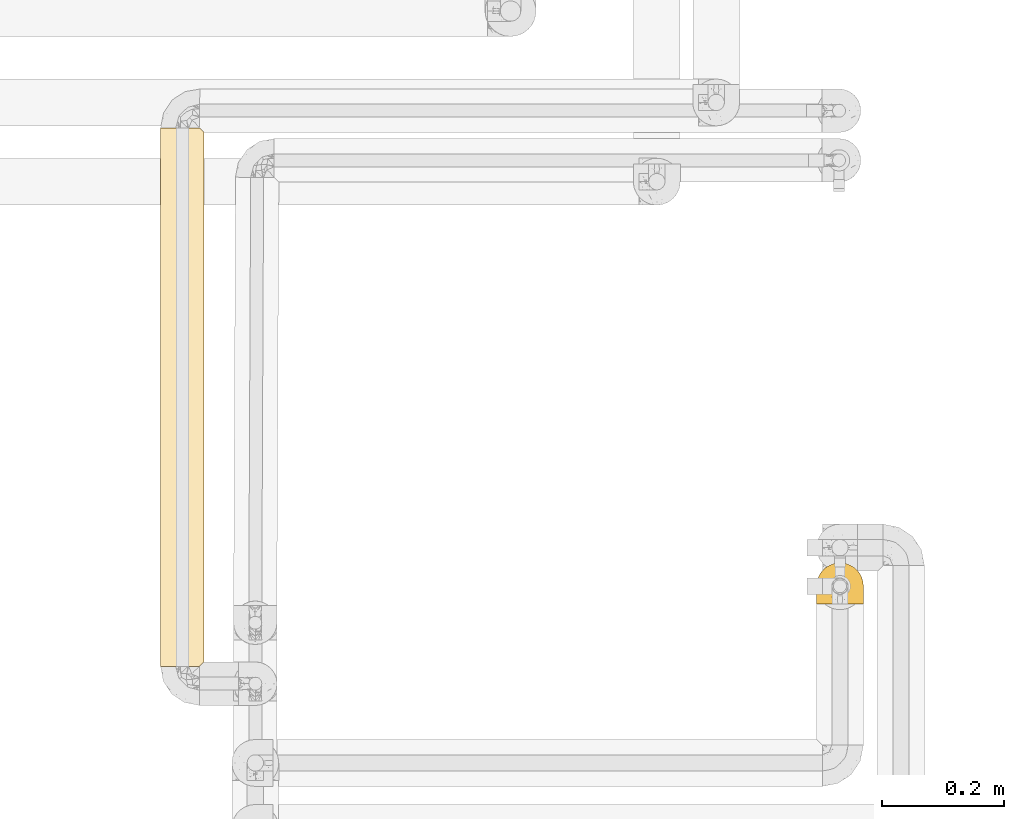
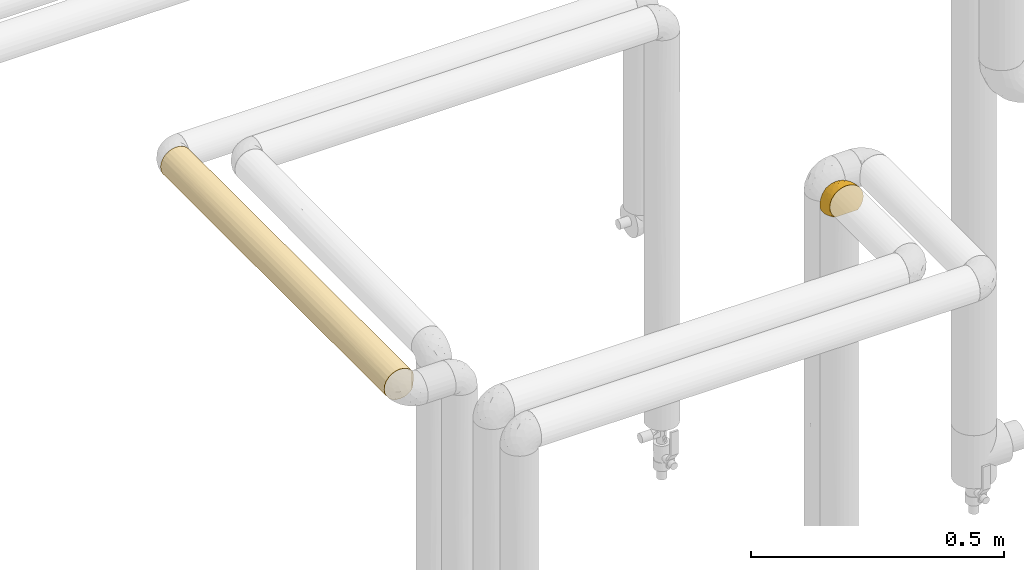
# One storey, part 87 of 827: 2 coverings.
"""IFC2X3 building model written with IfcOpenShell, lengths in millimetres."""

from ifc_helpers import new_model, entity, si_unit, converted_unit, derived_unit, direction, frame, origin, place, context, subcontext, project, spatial, faceted_brep, element, save


model = new_model("IFC2X3")

# Units and contexts
model_context = context("Model", 3, precision=0.01, world=origin(), true_north=direction((6.12303176911189e-17, 1.0)))
body_context = subcontext(model_context, "Body", "Model", "MODEL_VIEW")
ifc_project = project(units=[si_unit("LENGTHUNIT", "METRE", prefix="MILLI"), si_unit("AREAUNIT", "SQUARE_METRE"), si_unit("VOLUMEUNIT", "CUBIC_METRE"), converted_unit("PLANEANGLEUNIT", "DEGREE", entity("IfcRatioMeasure", 0.0174532925199433), si_unit("PLANEANGLEUNIT", "RADIAN"), dimensions=[0, 0, 0, 0, 0, 0, 0]), si_unit("MASSUNIT", "GRAM", prefix="KILO"), derived_unit("MASSDENSITYUNIT", [(si_unit("MASSUNIT", "GRAM", prefix="KILO"), 1), (si_unit("LENGTHUNIT", "METRE"), -3)]), derived_unit("MOMENTOFINERTIAUNIT", [(si_unit("LENGTHUNIT", "METRE"), 4)]), si_unit("TIMEUNIT", "SECOND"), si_unit("FREQUENCYUNIT", "HERTZ"), si_unit("THERMODYNAMICTEMPERATUREUNIT", "DEGREE_CELSIUS"), derived_unit("THERMALTRANSMITTANCEUNIT", [(si_unit("MASSUNIT", "GRAM", prefix="KILO"), 1), (si_unit("THERMODYNAMICTEMPERATUREUNIT", "KELVIN"), -1), (si_unit("TIMEUNIT", "SECOND"), -3)]), derived_unit("VOLUMETRICFLOWRATEUNIT", [(si_unit("LENGTHUNIT", "METRE"), 3), (si_unit("TIMEUNIT", "SECOND"), -1)]), derived_unit("MASSFLOWRATEUNIT", [(si_unit("MASSUNIT", "GRAM", prefix="KILO"), 1), (si_unit("TIMEUNIT", "SECOND"), -1)]), derived_unit("ROTATIONALFREQUENCYUNIT", [(si_unit("TIMEUNIT", "SECOND"), -1)]), si_unit("ELECTRICCURRENTUNIT", "AMPERE"), si_unit("ELECTRICVOLTAGEUNIT", "VOLT"), si_unit("POWERUNIT", "WATT"), si_unit("FORCEUNIT", "NEWTON", prefix="KILO"), si_unit("ILLUMINANCEUNIT", "LUX"), si_unit("LUMINOUSFLUXUNIT", "LUMEN"), si_unit("LUMINOUSINTENSITYUNIT", "CANDELA"), derived_unit("USERDEFINED", [(si_unit("MASSUNIT", "GRAM", prefix="KILO"), -1), (si_unit("LENGTHUNIT", "METRE"), -2), (si_unit("TIMEUNIT", "SECOND"), 3), (si_unit("LUMINOUSFLUXUNIT", "LUMEN"), 1)]), derived_unit("LINEARVELOCITYUNIT", [(si_unit("LENGTHUNIT", "METRE"), 1), (si_unit("TIMEUNIT", "SECOND"), -1)]), si_unit("PRESSUREUNIT", "PASCAL"), derived_unit("USERDEFINED", [(si_unit("LENGTHUNIT", "METRE"), -2), (si_unit("MASSUNIT", "GRAM", prefix="KILO"), 1), (si_unit("TIMEUNIT", "SECOND"), -2)]), derived_unit("LINEARFORCEUNIT", [(si_unit("MASSUNIT", "GRAM", prefix="KILO"), 1), (si_unit("LENGTHUNIT", "METRE"), 1), (si_unit("TIMEUNIT", "SECOND"), -2), (si_unit("LENGTHUNIT", "METRE"), -1)]), derived_unit("PLANARFORCEUNIT", [(si_unit("MASSUNIT", "GRAM", prefix="KILO"), 1), (si_unit("LENGTHUNIT", "METRE"), 1), (si_unit("TIMEUNIT", "SECOND"), -2), (si_unit("LENGTHUNIT", "METRE"), -2)])], contexts=[model_context])

# Site, building, storey
site_placement = place(None, origin())
site = spatial("IfcSite", under=ifc_project, at=site_placement, CompositionType="ELEMENT")
building_placement = place(site_placement, origin())
building = spatial("IfcBuilding", under=site, at=building_placement, CompositionType="ELEMENT")
storey_placement = place(building_placement, frame((0.0, 0.0, 28200.0)))
storey = spatial("IfcBuildingStorey", under=building, at=storey_placement, Name="08", CompositionType="ELEMENT", Elevation=28200.0)

# Coverings
covering_1_placement = place(storey_placement, frame((18846.09, 12125.48, 1869.3)))
element("IfcCovering", 1, at=covering_1_placement, inside=storey, Name=":ADSK_", ObjectType=":ADSK_", PredefinedType="INSULATION", context=body_context, shape_type="Brep", body=[
    faceted_brep([(5.41, 47.38, 1.6), (9.99, 54.67, 1.6), (16.08, 60.76, 1.6), (23.37, 65.34, 1.6), (31.49, 68.18, 1.6), (40.05, 69.15, 1.6), (48.61, 68.18, 1.6), (56.73, 65.33, 1.6), (64.02, 60.75, 1.6), (70.11, 54.66, 1.6), (74.69, 47.37, 1.6), (77.53, 39.25, 1.6), (78.5, 30.7, 1.6), (77.63, 22.59, 1.6), (75.08, 14.86, 1.6), (70.97, 7.84, 1.6), (65.47, 1.85, 1.6), (63.27, 1.85, 1.6), (61.53, 1.85, 1.6), (59.57, 1.85, 1.6), (57.6, 1.85, 1.6), (55.63, 1.85, 1.6), (53.67, 1.85, 1.6), (51.7, 1.85, 1.6), (49.73, 1.85, 1.6), (47.54, 1.85, 1.6), (45.34, 1.85, 1.6), (43.15, 1.85, 1.6), (40.96, 1.85, 1.6), (38.76, 1.85, 1.6), (36.57, 1.85, 1.6), (34.37, 1.85, 1.6), (32.18, 1.85, 1.6), (29.98, 1.85, 1.6), (27.79, 1.85, 1.6), (25.6, 1.85, 1.6), (23.4, 1.85, 1.6), (21.21, 1.85, 1.6), (19.01, 1.85, 1.6), (16.82, 1.85, 1.6), (14.62, 1.85, 1.6), (9.12, 7.85, 1.6), (5.0, 14.88, 1.6), (2.46, 22.61, 1.6), (1.6, 30.7, 1.6), (2.56, 39.26, 1.6), (65.47, 1.6, 1.85), (70.97, 1.6, 7.85), (75.09, 1.6, 14.87), (77.63, 1.6, 22.6), (78.5, 1.6, 30.7), (77.19, 1.6, 40.65), (73.34, 1.6, 49.92), (67.23, 1.6, 57.88), (59.27, 1.6, 63.99), (50.0, 1.6, 67.84), (40.05, 1.6, 69.15), (30.09, 1.6, 67.84), (20.82, 1.6, 63.99), (12.86, 1.6, 57.88), (6.75, 1.6, 49.92), (2.91, 1.6, 40.65), (1.6, 1.6, 30.7), (2.46, 1.6, 22.6), (5.0, 1.6, 14.87), (9.12, 1.6, 7.85), (14.62, 1.6, 1.85), (16.82, 1.6, 1.85), (17.8, 1.6, 1.85), (19.39, 1.6, 1.85), (20.98, 1.6, 1.85), (22.57, 1.6, 1.85), (24.16, 1.6, 1.85), (25.75, 1.6, 1.85), (27.33, 1.6, 1.85), (28.92, 1.6, 1.85), (30.51, 1.6, 1.85), (32.1, 1.6, 1.85), (33.69, 1.6, 1.85), (35.28, 1.6, 1.85), (36.87, 1.6, 1.85), (38.46, 1.6, 1.85), (40.05, 1.6, 1.85), (41.63, 1.6, 1.85), (43.22, 1.6, 1.85), (44.81, 1.6, 1.85), (46.4, 1.6, 1.85), (47.99, 1.6, 1.85), (49.58, 1.6, 1.85), (51.17, 1.6, 1.85), (52.76, 1.6, 1.85), (54.72, 1.6, 1.85), (56.69, 1.6, 1.85), (58.88, 1.6, 1.85), (61.08, 1.6, 1.85), (63.27, 1.6, 1.85), (37.77, 1.78, 1.77), (36.07, 1.77, 1.78), (32.96, 1.78, 1.77), (31.36, 1.77, 1.77), (56.52, 1.79, 1.76), (54.96, 1.78, 1.77), (18.75, 1.76, 1.79), (58.07, 1.77, 1.78), (50.37, 1.77, 1.78), (23.36, 1.76, 1.78), (24.95, 1.77, 1.78), (42.43, 1.77, 1.78), (15.97, 1.8, 1.74), (51.96, 1.76, 1.78), (53.47, 1.77, 1.78), (48.63, 1.78, 1.77), (63.93, 1.77, 1.78), (40.93, 1.77, 1.78), (29.72, 1.76, 1.78), (62.4, 1.77, 1.77), (60.92, 1.78, 1.77), (17.31, 1.77, 1.77), (21.74, 1.77, 1.78), (34.56, 1.77, 1.78), (20.18, 1.78, 1.77), (14.62, 1.77, 1.77), (14.62, 1.8, 1.72), (14.62, 1.82, 1.66), (65.47, 1.77, 1.77), (65.47, 1.72, 1.8), (65.47, 1.66, 1.82), (59.5, 1.76, 1.79), (47.1, 1.77, 1.78), (45.61, 1.76, 1.79), (28.18, 1.77, 1.78), (14.62, 1.66, 1.82), (14.62, 1.72, 1.8), (26.61, 1.78, 1.76), (65.47, 1.82, 1.66), (65.47, 1.8, 1.72), (39.32, 1.77, 1.78), (44.12, 1.78, 1.77), (72.26, 3.72, 9.41), (76.57, 7.41, 17.65), (71.77, 6.13, 7.41), (78.5, 21.47, 21.47), (77.9, 19.34, 15.21), (78.5, 26.8, 16.15), (78.5, 8.87, 28.75), (75.52, 9.2, 13.67), (76.13, 12.79, 12.79), (77.81, 14.62, 19.18), (78.5, 7.34, 29.16), (72.4, 5.33, 9.04), (76.56, 17.64, 7.41), (71.77, 7.7, 5.74), (72.25, 9.41, 3.72), (78.5, 28.75, 8.87), (78.5, 16.15, 26.8), (75.75, 14.14, 9.53), (78.5, 29.16, 7.34), (50.46, 57.02, 37.63), (52.75, 64.92, 17.92), (40.05, 64.0, 27.45), (77.7, 11.92, 37.01), (77.66, 19.16, 34.22), (71.02, 28.65, 45.87), (63.45, 24.62, 56.57), (70.55, 15.19, 52.31), (75.57, 18.36, 42.07), (75.57, 9.2, 44.74), (72.61, 46.98, 21.49), (72.61, 50.24, 11.02), (67.24, 56.1, 15.64), (77.74, 28.97, 26.02), (57.43, 54.46, 36.59), (47.19, 21.34, 65.49), (54.76, 18.4, 63.99), (40.05, 66.44, 15.2), (63.45, 12.07, 60.27), (60.1, 45.49, 45.25), (63.72, 50.57, 35.21), (76.83, 36.04, 22.52), (76.34, 42.07, 12.03), (60.51, 62.12, 13.32), (72.59, 37.37, 35.9), (76.05, 29.39, 33.87), (66.15, 53.59, 25.73), (60.51, 58.06, 26.34), (51.88, 49.27, 46.78), (55.34, 29.63, 59.54), (48.67, 33.21, 60.18), (53.89, 40.1, 53.93), (46.73, 44.08, 53.36), (40.05, 49.36, 49.36), (40.05, 56.68, 38.4), (40.05, 15.2, 66.44), (63.95, 35.57, 50.09), (67.24, 41.7, 41.08), (69.62, 46.4, 31.14), (73.6, 41.41, 28.19), (40.05, 27.45, 64.0), (40.05, 38.4, 56.68), (4.52, 12.99, 43.9), (32.72, 21.33, 65.46), (27.18, 42.89, 52.22), (29.63, 57.04, 37.61), (12.86, 56.11, 15.64), (19.59, 62.13, 13.31), (9.54, 21.89, 50.02), (16.64, 16.62, 59.28), (17.48, 32.9, 53.05), (7.49, 46.99, 21.48), (7.49, 50.25, 11.01), (3.75, 42.08, 12.03), (20.75, 49.91, 41.02), (2.33, 15.6, 35.39), (1.6, 16.15, 26.8), (1.6, 8.87, 28.75), (1.6, 29.16, 7.34), (26.94, 13.16, 65.81), (9.54, 10.83, 53.28), (31.21, 33.8, 59.8), (25.33, 25.02, 61.82), (27.35, 64.92, 17.91), (8.17, 32.83, 41.4), (4.3, 20.56, 40.48), (19.59, 58.07, 26.34), (2.23, 21.46, 31.68), (2.45, 28.1, 27.68), (1.6, 26.8, 16.15), (1.6, 21.47, 21.47), (12.86, 51.29, 28.05), (3.27, 36.04, 22.54), (1.6, 28.75, 8.87), (2.29, 8.45, 37.3), (12.86, 41.73, 41.07), (6.89, 39.27, 32.24), (12.43, 33.56, 47.4), (4.1, 27.29, 35.77), (3.53, 7.41, 17.65), (6.88, 3.51, 11.06), (8.16, 4.68, 8.55), (9.02, 5.52, 6.63), (5.0, 8.75, 12.77), (3.96, 12.79, 12.79), (3.52, 17.65, 7.41), (2.4, 13.9, 18.97), (7.83, 9.42, 3.72), (8.32, 7.68, 5.76), (2.19, 19.33, 15.21), (4.34, 14.13, 9.52)], [[[0, 1, 2, 3, 4, 5, 6, 7, 8, 9, 10, 11, 12, 13, 14, 15, 16, 17, 18, 19, 20, 21, 22, 23, 24, 25, 26, 27, 28, 29, 30, 31, 32, 33, 34, 35, 36, 37, 38, 39, 40, 41, 42, 43, 44, 45]], [[46, 47, 48, 49, 50, 51, 52, 53, 54, 55, 56, 57, 58, 59, 60, 61, 62, 63, 64, 65, 66, 67, 68, 69, 70, 71, 72, 73, 74, 75, 76, 77, 78, 79, 80, 81, 82, 83, 84, 85, 86, 87, 88, 89, 90, 91, 92, 93, 94, 95]], [[96, 97, 30]], [[98, 77, 99]], [[100, 101, 21]], [[69, 68, 102]], [[20, 19, 103]], [[24, 23, 104]], [[20, 103, 100]], [[72, 105, 106]], [[84, 83, 107]], [[89, 88, 104]], [[108, 67, 66]], [[109, 110, 90]], [[111, 25, 24]], [[112, 17, 16]], [[82, 113, 83]], [[109, 23, 22]], [[114, 76, 75]], [[105, 36, 106]], [[104, 111, 24]], [[18, 115, 116]], [[97, 96, 80]], [[67, 108, 117]], [[105, 71, 118]], [[31, 97, 119]], [[102, 120, 69]], [[108, 121, 122, 123, 40]], [[112, 95, 115]], [[17, 115, 18]], [[94, 116, 115]], [[117, 68, 67]], [[38, 117, 39]], [[112, 124, 125, 126, 46]], [[17, 112, 115]], [[70, 120, 118]], [[39, 117, 108]], [[120, 38, 37]], [[120, 37, 118]], [[120, 70, 69]], [[116, 94, 127]], [[128, 86, 129]], [[117, 38, 102]], [[74, 130, 75]], [[99, 33, 32]], [[115, 95, 94]], [[39, 108, 40]], [[108, 66, 131, 132, 121]], [[105, 72, 71]], [[118, 37, 36]], [[71, 70, 118]], [[35, 106, 36]], [[36, 105, 118]], [[35, 133, 106]], [[74, 73, 133]], [[106, 133, 73]], [[99, 114, 33]], [[133, 35, 34]], [[73, 72, 106]], [[95, 112, 46]], [[112, 16, 134, 135, 124]], [[130, 114, 75]], [[99, 76, 114]], [[114, 130, 33]], [[34, 33, 130]], [[78, 77, 98]], [[98, 119, 78]], [[130, 133, 34]], [[133, 130, 74]], [[79, 97, 80]], [[98, 99, 32]], [[98, 32, 31]], [[77, 76, 99]], [[97, 79, 119]], [[136, 96, 29]], [[30, 97, 31]], [[136, 29, 28]], [[81, 80, 96]], [[29, 96, 30]], [[31, 119, 98]], [[119, 79, 78]], [[96, 136, 81]], [[82, 81, 136]], [[113, 107, 83]], [[84, 107, 137]], [[107, 27, 137]], [[113, 28, 107]], [[27, 107, 28]], [[85, 84, 137]], [[137, 27, 26]], [[113, 136, 28]], [[136, 113, 82]], [[109, 89, 104]], [[86, 85, 129]], [[89, 109, 90]], [[111, 87, 128]], [[26, 129, 137]], [[88, 111, 104]], [[25, 111, 128]], [[22, 110, 109]], [[23, 109, 104]], [[110, 91, 90]], [[100, 92, 101]], [[110, 22, 101]], [[91, 110, 101]], [[116, 19, 18]], [[111, 88, 87]], [[127, 103, 19]], [[25, 128, 26]], [[86, 128, 87]], [[128, 129, 26]], [[137, 129, 85]], [[120, 102, 38]], [[117, 102, 68]], [[91, 101, 92]], [[21, 101, 22]], [[93, 92, 103]], [[100, 21, 20]], [[100, 103, 92]], [[127, 93, 103]], [[93, 127, 94]], [[116, 127, 19]], [[126, 138, 47]], [[48, 138, 139]], [[140, 125, 124]], [[141, 142, 143]], [[144, 49, 139]], [[145, 140, 146]], [[48, 139, 49]], [[139, 145, 147]], [[49, 144, 148, 50]], [[126, 125, 149]], [[14, 13, 150]], [[151, 146, 140]], [[149, 140, 145]], [[152, 151, 135]], [[152, 14, 150]], [[16, 15, 134]], [[13, 153, 150]], [[124, 151, 140]], [[141, 147, 142]], [[14, 152, 15]], [[15, 152, 134]], [[47, 46, 126]], [[139, 154, 144]], [[138, 48, 47]], [[125, 140, 149]], [[135, 134, 152]], [[146, 155, 142]], [[145, 146, 147]], [[149, 139, 138]], [[147, 141, 154]], [[147, 146, 142]], [[139, 147, 154]], [[139, 149, 145]], [[149, 138, 126]], [[155, 146, 151]], [[150, 143, 142]], [[152, 155, 151]], [[150, 142, 155]], [[13, 12, 156, 153]], [[153, 143, 150]], [[152, 150, 155]], [[151, 124, 135]], [[157, 158, 159]], [[160, 154, 161]], [[162, 163, 164]], [[165, 166, 160]], [[167, 168, 169]], [[141, 170, 161]], [[156, 12, 11]], [[158, 157, 171]], [[172, 55, 173]], [[158, 6, 174]], [[175, 54, 53]], [[52, 166, 164]], [[52, 164, 53]], [[54, 175, 173]], [[166, 52, 51]], [[176, 177, 171]], [[178, 143, 179]], [[156, 11, 179]], [[8, 7, 180]], [[169, 9, 8]], [[179, 143, 153, 156]], [[179, 11, 10]], [[168, 179, 10]], [[181, 162, 182]], [[179, 167, 178]], [[183, 184, 177]], [[183, 169, 184]], [[176, 171, 185]], [[172, 186, 187]], [[158, 7, 6]], [[159, 158, 174]], [[184, 180, 158]], [[54, 173, 55]], [[180, 169, 8]], [[188, 189, 187]], [[9, 168, 10]], [[186, 188, 187]], [[190, 157, 159, 191]], [[55, 172, 192]], [[176, 193, 194]], [[161, 170, 182]], [[162, 164, 165]], [[175, 164, 163]], [[51, 50, 148]], [[167, 195, 196]], [[178, 182, 170]], [[6, 5, 174]], [[158, 180, 7]], [[169, 180, 184]], [[169, 168, 9]], [[179, 168, 167]], [[182, 162, 165]], [[162, 194, 193]], [[161, 165, 160]], [[195, 181, 196]], [[192, 172, 197]], [[192, 56, 55]], [[189, 190, 198]], [[198, 197, 187]], [[172, 187, 197]], [[185, 189, 188]], [[198, 187, 189]], [[186, 172, 173]], [[173, 163, 186]], [[193, 186, 163]], [[176, 185, 188]], [[185, 157, 190]], [[188, 186, 193]], [[177, 176, 194]], [[188, 193, 176]], [[162, 193, 163]], [[195, 177, 194]], [[171, 177, 184]], [[181, 195, 194]], [[183, 167, 169]], [[162, 181, 194]], [[196, 182, 178]], [[158, 171, 184]], [[171, 157, 185]], [[177, 195, 183]], [[167, 183, 195]], [[182, 196, 181]], [[178, 170, 143]], [[178, 167, 196]], [[164, 175, 53]], [[173, 175, 163]], [[160, 51, 148]], [[164, 166, 165]], [[51, 160, 166]], [[160, 148, 144, 154]], [[141, 161, 154]], [[182, 165, 161]], [[190, 189, 185]], [[143, 170, 141]], [[60, 199, 61]], [[197, 200, 192]], [[201, 190, 202]], [[200, 57, 192]], [[203, 204, 2]], [[205, 206, 207]], [[208, 209, 210]], [[211, 207, 201]], [[212, 213, 214]], [[45, 215, 210]], [[216, 206, 58]], [[45, 44, 215]], [[59, 217, 60]], [[60, 217, 199]], [[0, 45, 210]], [[218, 201, 219]], [[202, 159, 220]], [[205, 221, 222]], [[223, 204, 203]], [[1, 203, 2]], [[57, 200, 216]], [[220, 3, 204]], [[220, 174, 4]], [[1, 0, 209]], [[212, 224, 213]], [[225, 226, 227]], [[228, 223, 203]], [[208, 210, 229]], [[210, 226, 229]], [[3, 220, 4]], [[58, 206, 59]], [[209, 203, 1]], [[202, 220, 223]], [[228, 203, 208]], [[202, 211, 201]], [[3, 2, 204]], [[202, 190, 191, 159]], [[210, 215, 230, 226]], [[199, 212, 231]], [[232, 233, 221]], [[233, 208, 229]], [[207, 206, 219]], [[217, 206, 205]], [[227, 224, 225]], [[233, 232, 228]], [[201, 207, 219]], [[234, 232, 221]], [[218, 219, 200]], [[202, 223, 211]], [[174, 220, 159]], [[174, 5, 4]], [[61, 231, 62]], [[220, 204, 223]], [[210, 209, 0]], [[203, 209, 208]], [[225, 233, 229]], [[224, 227, 213]], [[221, 233, 235]], [[57, 56, 192]], [[198, 218, 197]], [[200, 219, 216]], [[201, 198, 190]], [[197, 218, 200]], [[198, 201, 218]], [[206, 216, 219]], [[58, 57, 216]], [[231, 212, 214]], [[222, 212, 199]], [[228, 211, 223]], [[207, 211, 232]], [[62, 231, 214]], [[199, 231, 61]], [[233, 228, 208]], [[211, 228, 232]], [[222, 221, 235]], [[234, 205, 207]], [[206, 217, 59]], [[199, 217, 205]], [[205, 222, 199]], [[224, 222, 235]], [[222, 224, 212]], [[224, 235, 225]], [[233, 225, 235]], [[226, 225, 229]], [[205, 234, 221]], [[207, 232, 234]], [[63, 214, 236]], [[214, 213, 236]], [[214, 63, 62]], [[237, 236, 238]], [[238, 132, 131]], [[236, 237, 64]], [[239, 240, 241]], [[63, 236, 64]], [[131, 66, 65]], [[237, 131, 65]], [[242, 230, 43]], [[237, 65, 64]], [[239, 121, 132]], [[42, 242, 43]], [[241, 240, 243]], [[41, 123, 244]], [[43, 230, 215, 44]], [[244, 122, 245]], [[227, 246, 243]], [[241, 247, 245]], [[121, 239, 245]], [[41, 40, 123]], [[132, 238, 239]], [[244, 42, 41]], [[131, 237, 238]], [[240, 239, 238]], [[245, 239, 241]], [[247, 241, 246]], [[247, 244, 245]], [[238, 236, 240]], [[243, 236, 213]], [[236, 243, 240]], [[227, 226, 246]], [[243, 213, 227]], [[242, 246, 226]], [[243, 246, 241]], [[246, 242, 247]], [[244, 247, 242]], [[242, 226, 230]], [[42, 244, 242]], [[122, 244, 123]], [[122, 121, 245]]]),
])
covering_2_placement = place(storey_placement, frame((17769.65, 12022.61, 1862.75)))
element("IfcCovering", 2, at=covering_2_placement, inside=storey, Name=":ADSK_", ObjectType=":ADSK_", PredefinedType="INSULATION", context=body_context, shape_type="Brep", body=[
    faceted_brep([(12.04, 1.6, 12.04), (19.42, 1.6, 6.37), (28.02, 1.6, 2.81), (37.25, 1.6, 1.6), (45.24, 1.6, 2.5), (52.81, 1.6, 5.17), (59.6, 1.6, 9.47), (65.25, 1.6, 15.18), (65.25, 1.6, 59.31), (59.6, 1.6, 65.02), (52.81, 1.6, 69.32), (45.24, 1.6, 71.99), (37.25, 1.6, 72.9), (28.02, 1.6, 71.68), (19.42, 1.6, 68.12), (12.04, 1.6, 62.45), (6.37, 1.6, 55.07), (2.81, 1.6, 46.47), (1.6, 1.6, 37.25), (2.81, 1.6, 28.02), (6.37, 1.6, 19.42), (28.02, 885.84, 2.81), (19.42, 885.84, 6.37), (12.04, 885.84, 12.04), (6.37, 885.84, 19.42), (2.81, 885.84, 28.02), (1.6, 885.84, 37.25), (2.81, 885.84, 46.47), (6.37, 885.84, 55.07), (12.04, 885.84, 62.45), (19.42, 885.84, 68.12), (28.02, 885.84, 71.68), (37.25, 885.84, 72.9), (45.23, 885.84, 71.99), (52.81, 885.84, 69.32), (59.59, 885.84, 65.02), (65.24, 885.84, 59.31), (65.24, 885.84, 15.18), (59.59, 885.84, 9.47), (52.81, 885.84, 5.17), (45.23, 885.84, 2.5), (37.25, 885.84, 1.6), (8.96, 685.23, 15.54), (1.6, 210.08, 37.25), (1.6, 677.36, 37.25), (3.07, 573.12, 27.11), (37.25, 677.36, 1.6), (37.25, 210.08, 1.6), (30.79, 353.84, 2.18), (26.19, 200.07, 3.35), (23.6, 390.04, 4.31), (5.79, 564.47, 20.46), (1.6, 468.88, 37.25), (30.46, 573.12, 2.25), (23.6, 656.18, 4.31), (4.31, 281.62, 23.6), (15.54, 265.65, 8.96), (2.17, 339.48, 30.86), (15.54, 603.42, 8.96), (8.96, 443.72, 15.54), (8.96, 202.2, 15.54), (37.25, 468.88, 1.6), (37.25, 235.24, 1.6), (47.35, 573.12, 3.06), (66.9, 247.87, 17.45), (69.75, 443.72, 22.6), (71.77, 252.79, 28.34), (72.22, 443.74, 30.35), (72.9, 660.95, 37.25), (72.9, 652.2, 37.25), (72.9, 443.72, 37.25), (72.9, 426.21, 37.25), (72.9, 226.48, 37.25), (56.32, 679.98, 7.13), (68.52, 882.56, 20.13), (66.9, 639.54, 17.45), (56.32, 207.44, 7.13), (49.1, 268.29, 3.62), (56.32, 443.71, 7.13), (61.92, 325.57, 11.52), (72.4, 8.75, 31.32), (72.9, 217.73, 37.25), (72.9, 9.25, 37.25), (71.77, 634.67, 28.34), (70.93, 880.15, 25.57), (72.4, 878.68, 31.32), (68.52, 4.87, 20.14), (62.23, 693.0, 11.81), (70.93, 7.28, 25.57), (63.79, 506.9, 13.45), (72.9, 878.19, 37.25), (70.93, 880.15, 48.92), (71.76, 586.53, 46.16), (72.4, 878.68, 43.17), (68.52, 882.56, 54.36), (66.91, 672.3, 57.02), (72.4, 8.75, 43.17), (71.76, 288.86, 46.16), (70.93, 7.28, 48.92), (49.1, 255.92, 70.87), (37.25, 235.23, 72.9), (49.1, 606.27, 70.87), (56.32, 190.35, 67.36), (37.25, 468.87, 72.9), (37.25, 418.56, 72.9), (66.91, 215.13, 57.02), (62.29, 325.46, 62.61), (61.85, 562.2, 63.04), (56.32, 411.9, 67.36), (68.52, 4.87, 54.35), (66.82, 443.71, 57.14), (37.25, 677.36, 72.9), (56.05, 636.25, 67.53), (37.25, 210.08, 72.9), (15.54, 685.23, 65.53), (23.6, 603.42, 70.18), (15.54, 202.2, 65.53), (8.96, 265.65, 58.95), (8.96, 603.42, 58.95), (4.31, 390.04, 50.89), (23.6, 284.01, 70.18), (15.54, 443.72, 65.53), (30.72, 538.22, 72.29), (30.71, 314.32, 72.29), (2.25, 573.12, 44.03), (4.31, 656.18, 50.89), (3.35, 200.07, 48.3), (2.18, 353.84, 43.7)], [[[0, 1, 2, 3, 4, 5, 6, 7, 8, 9, 10, 11, 12, 13, 14, 15, 16, 17, 18, 19, 20]], [[21, 22, 23, 24, 25, 26, 27, 28, 29, 30, 31, 32, 33, 34, 35, 36, 37, 38, 39, 40, 41]], [[24, 23, 42]], [[19, 18, 43]], [[44, 26, 25]], [[24, 45, 25]], [[45, 44, 25]], [[21, 41, 46]], [[47, 3, 2]], [[48, 49, 50]], [[51, 24, 42]], [[45, 52, 44]], [[46, 53, 21]], [[21, 54, 22]], [[19, 55, 20]], [[1, 0, 56]], [[53, 50, 54]], [[55, 45, 51]], [[43, 52, 57]], [[56, 49, 1]], [[23, 22, 58]], [[58, 56, 59, 42]], [[54, 58, 22]], [[56, 50, 49]], [[60, 55, 59]], [[56, 58, 54, 50]], [[20, 60, 0]], [[60, 56, 0]], [[57, 45, 55]], [[43, 57, 19]], [[48, 50, 53]], [[53, 46, 61]], [[53, 61, 48]], [[21, 53, 54]], [[48, 61, 62, 47]], [[49, 47, 2]], [[47, 49, 48]], [[1, 49, 2]], [[58, 42, 23]], [[51, 42, 59]], [[55, 60, 20]], [[56, 60, 59]], [[45, 57, 52]], [[19, 57, 55]], [[55, 51, 59]], [[24, 51, 45]], [[46, 41, 40]], [[46, 63, 61]], [[64, 65, 66]], [[67, 68, 69, 70, 71, 72]], [[39, 73, 63]], [[74, 75, 37]], [[76, 77, 78]], [[4, 77, 5]], [[63, 77, 61]], [[79, 7, 6]], [[80, 72, 81, 82]], [[4, 62, 77]], [[67, 65, 83]], [[6, 5, 76]], [[39, 63, 40]], [[83, 75, 84]], [[38, 73, 39]], [[83, 84, 85]], [[64, 86, 7]], [[37, 75, 87]], [[80, 66, 72]], [[46, 40, 63]], [[79, 6, 76]], [[85, 68, 83]], [[88, 86, 64]], [[80, 88, 66]], [[65, 75, 83]], [[64, 66, 88]], [[89, 65, 64]], [[89, 78, 87]], [[74, 84, 75]], [[65, 67, 66]], [[79, 89, 64]], [[63, 78, 77]], [[77, 76, 5]], [[79, 76, 78]], [[87, 73, 38]], [[63, 73, 78]], [[78, 73, 87]], [[79, 64, 7]], [[37, 87, 38]], [[89, 87, 75]], [[89, 75, 65]], [[78, 89, 79]], [[67, 72, 66]], [[68, 85, 90]], [[68, 67, 83]], [[4, 3, 47, 62]], [[62, 61, 77]], [[91, 92, 93]], [[94, 36, 95]], [[96, 97, 98]], [[99, 100, 11]], [[34, 33, 101]], [[93, 69, 68, 90]], [[92, 91, 95]], [[69, 93, 92]], [[10, 9, 102]], [[99, 103, 104, 100]], [[98, 97, 105]], [[106, 107, 108]], [[96, 81, 97]], [[95, 91, 94]], [[105, 8, 109]], [[103, 99, 101]], [[110, 95, 107]], [[101, 33, 111]], [[108, 107, 112]], [[107, 36, 35]], [[92, 95, 110]], [[102, 99, 10]], [[105, 106, 8]], [[112, 101, 108]], [[103, 101, 111]], [[106, 9, 8]], [[105, 109, 98]], [[110, 97, 92]], [[11, 10, 99]], [[71, 92, 97]], [[105, 110, 106]], [[11, 100, 113, 12]], [[108, 101, 99]], [[105, 97, 110]], [[36, 107, 95]], [[35, 34, 112]], [[33, 32, 111]], [[107, 106, 110]], [[106, 108, 102]], [[106, 102, 9]], [[99, 102, 108]], [[35, 112, 107]], [[34, 101, 112]], [[92, 71, 70, 69]], [[81, 96, 82]], [[97, 81, 72, 71]], [[114, 115, 30]], [[116, 117, 15]], [[117, 118, 119]], [[116, 120, 115, 114, 121]], [[30, 115, 31]], [[122, 115, 120]], [[29, 114, 30]], [[123, 113, 100, 104]], [[116, 15, 14]], [[14, 13, 120]], [[28, 118, 29]], [[118, 117, 116, 121, 114]], [[124, 119, 125]], [[32, 31, 111]], [[13, 12, 113]], [[117, 126, 16]], [[119, 126, 117]], [[16, 15, 117]], [[27, 125, 28]], [[27, 26, 44]], [[43, 18, 17]], [[13, 113, 123]], [[123, 122, 120]], [[125, 118, 28]], [[127, 126, 119]], [[122, 31, 115]], [[44, 124, 27]], [[127, 119, 124]], [[118, 125, 119]], [[124, 44, 52]], [[124, 52, 127]], [[27, 124, 125]], [[52, 43, 127]], [[126, 43, 17]], [[43, 126, 127]], [[16, 126, 17]], [[123, 104, 122]], [[13, 123, 120]], [[122, 104, 103, 111]], [[31, 122, 111]], [[120, 116, 14]], [[118, 114, 29]], [[7, 86, 88, 80, 82, 96, 98, 109, 8]], [[36, 94, 91, 93, 90, 85, 84, 74, 37]]]),
])

save(model, "model.ifc")
